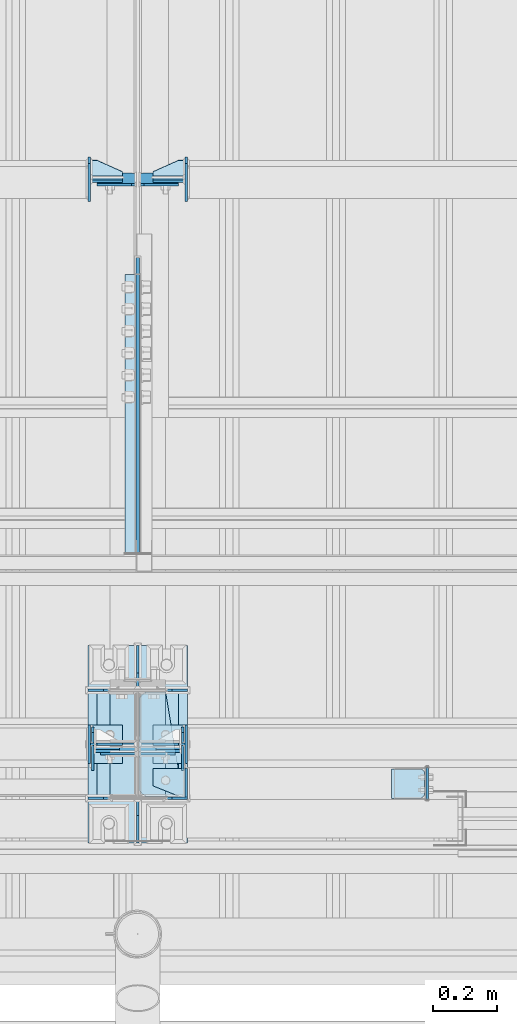
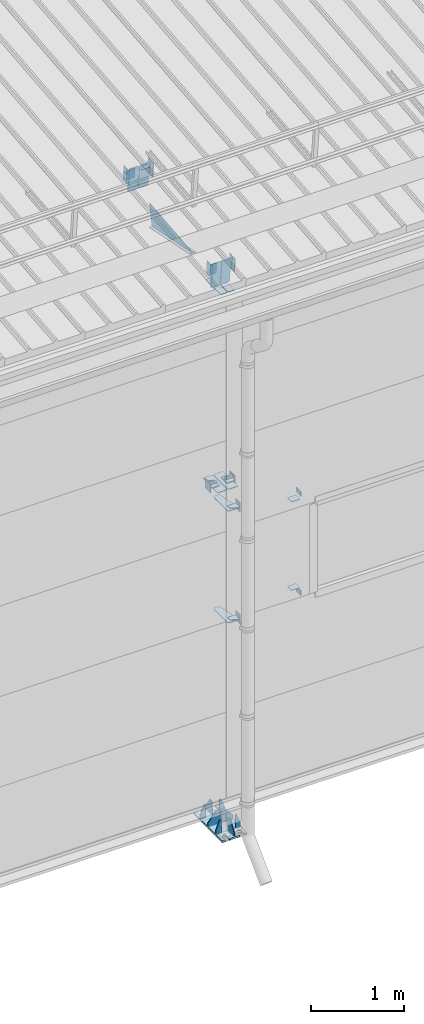
# One storey, part 121 of 709: 45 plates, 4 openings, 11 elements without a shape of their own.
"""IFC4 building model written with IfcOpenShell, lengths in millimetres."""

from ifc_helpers import new_model, si_unit, direction, frame, origin_with_axes, place, context, subcontext, project, spatial, line, arc, indexed_curve, outline, extrude, material, element, aggregate, save


model = new_model("IFC4")

# Units and contexts
model_context = context("Model", 3, precision=0.2, world=origin_with_axes(), true_north=direction((0.0, 1.0)))
body_context = subcontext(model_context, "Body", "Model", "MODEL_VIEW")
ifc_project = project(units=[si_unit("LENGTHUNIT", "METRE", prefix="MILLI"), si_unit("AREAUNIT", "SQUARE_METRE"), si_unit("VOLUMEUNIT", "CUBIC_METRE"), si_unit("MASSUNIT", "GRAM", prefix="KILO"), si_unit("TIMEUNIT", "SECOND"), si_unit("PLANEANGLEUNIT", "RADIAN"), si_unit("SOLIDANGLEUNIT", "STERADIAN"), si_unit("THERMODYNAMICTEMPERATUREUNIT", "DEGREE_CELSIUS"), si_unit("LUMINOUSINTENSITYUNIT", "LUMEN")], contexts=[model_context])

# Site, building, storey
site_placement = place(None, origin_with_axes())
site = spatial("IfcSite", under=ifc_project, at=site_placement, CompositionType="ELEMENT")
building_placement = place(site_placement, origin_with_axes())
building = spatial("IfcBuilding", under=site, at=building_placement, Name="Undefined", CompositionType="ELEMENT")
storey_placement = place(building_placement, origin_with_axes())
storey = spatial("IfcBuildingStorey", under=building, at=storey_placement, Name="Undefined", CompositionType="ELEMENT", Elevation=0.0)

# Assembly, plates, voiding features
assembly_1_placement = place(storey_placement, frame((16000.0, 173.0, -200.0), z_axis=(-1.0, 0.0, 0.0), x_axis=(0.0, 0.0, 1.0)))
assembly_1 = element("IfcElementAssembly", 1, at=assembly_1_placement, inside=storey)
ifc_material = material(Name="C355-6", Category="STEEL")
plate_1_placement = place(assembly_1_placement, frame((7434.21546, -30.02526, 3.0), z_axis=(-0.099503719, -0.9950371902, 0.0), x_axis=(0.0, 0.0, 1.0)))
plate_1 = element("IfcPlate", 2, at=plate_1_placement, material=ifc_material, ObjectType="595", context=body_context, shape_type="SolidModel", body=[
    extrude(outline(indexed_curve([(0.0, 0.0), (114.0, 0.0), (114.0, 333.33554), (0.0, 333.33554)], segments=[line(1, 2, 3, 4, 1)])), frame((0.0, 0.0, 4.0), z_axis=(0.0, 0.0, 1.0), x_axis=(1.0, 0.0, 0.0)), (0.0, 0.0, -1.0), 8.0),
])
plate_2_placement = place(assembly_1_placement, frame((12.5, -308.0, 155.0), z_axis=(1.0, 0.0, 0.0), x_axis=(0.0, 0.0, -1.0)))
plate_2 = element("IfcPlate", 3, at=plate_2_placement, material=ifc_material, ObjectType="416", context=body_context, shape_type="SolidModel", body=[
    extrude(outline(indexed_curve([(0.0, 0.0), (310.0, 0.0), (310.0, 616.0), (0.0, 616.0)], segments=[line(1, 2, 3, 4, 1)])), frame((0.0, 0.0, 12.5), z_axis=(0.0, 0.0, 1.0), x_axis=(1.0, 0.0, 0.0)), (0.0, 0.0, -1.0), 25.0),
])
voiding_feature_1_placement = place(plate_2_placement, frame((40.0, 616.0, 0.0), z_axis=(0.0, 0.0, -1.0), x_axis=(1.0, 0.0, 0.0)))
element("IfcVoidingFeature", 4, at=voiding_feature_1_placement, cuts=plate_2, PredefinedType="HOLE", context=body_context, shape_type="SolidModel", body=[
    extrude(outline(indexed_curve([(0.0, 0.0), (50.0, 0.0), (50.0, 60.0), (42.67767, 77.67767), (25.0, 85.0), (25.0, 85.0), (7.32233, 77.67767), (0.0, 60.0)], segments=[line(1, 2, 3), arc(3, 4, 5), line(5, 6), arc(6, 7, 8), line(8, 1)])), frame((0.0, 0.0, 12.5), z_axis=(0.0, 0.0, 1.0), x_axis=(1.0, 0.0, 0.0)), (0.0, 0.0, -1.0), 25.0),
])
voiding_feature_2_placement = place(plate_2_placement, frame((40.0, 0.0, 0.0), z_axis=(0.0, 0.0, 1.0), x_axis=(1.0, 0.0, 0.0)))
element("IfcVoidingFeature", 5, at=voiding_feature_2_placement, cuts=plate_2, PredefinedType="HOLE", context=body_context, shape_type="SolidModel", body=[
    extrude(outline(indexed_curve([(0.0, 0.0), (50.0, 0.0), (50.0, 60.0), (42.67767, 77.67767), (25.0, 85.0), (25.0, 85.0), (7.32233, 77.67767), (0.0, 60.0)], segments=[line(1, 2, 3), arc(3, 4, 5), line(5, 6), arc(6, 7, 8), line(8, 1)])), frame((0.0, 0.0, 12.5), z_axis=(0.0, 0.0, 1.0), x_axis=(1.0, 0.0, 0.0)), (0.0, 0.0, -1.0), 25.0),
])
voiding_feature_3_placement = place(plate_2_placement, frame((270.0, 616.0, 0.0), z_axis=(0.0, 0.0, 1.0), x_axis=(-1.0, 0.0, 0.0)))
element("IfcVoidingFeature", 6, at=voiding_feature_3_placement, cuts=plate_2, PredefinedType="HOLE", context=body_context, shape_type="SolidModel", body=[
    extrude(outline(indexed_curve([(0.0, 0.0), (50.0, 0.0), (50.0, 60.0), (42.67767, 77.67767), (25.0, 85.0), (25.0, 85.0), (7.32233, 77.67767), (0.0, 60.0)], segments=[line(1, 2, 3), arc(3, 4, 5), line(5, 6), arc(6, 7, 8), line(8, 1)])), frame((0.0, 0.0, 12.5), z_axis=(0.0, 0.0, 1.0), x_axis=(1.0, 0.0, 0.0)), (0.0, 0.0, -1.0), 25.0),
])
voiding_feature_4_placement = place(plate_2_placement, frame((270.0, 0.0, 0.0), z_axis=(0.0, 0.0, -1.0), x_axis=(-1.0, 0.0, 0.0)))
element("IfcVoidingFeature", 7, at=voiding_feature_4_placement, cuts=plate_2, PredefinedType="HOLE", context=body_context, shape_type="SolidModel", body=[
    extrude(outline(indexed_curve([(0.0, 0.0), (50.0, 0.0), (50.0, 60.0), (42.67767, 77.67767), (25.0, 85.0), (25.0, 85.0), (7.32233, 77.67767), (0.0, 60.0)], segments=[line(1, 2, 3), arc(3, 4, 5), line(5, 6), arc(6, 7, 8), line(8, 1)])), frame((0.0, 0.0, 12.5), z_axis=(0.0, 0.0, 1.0), x_axis=(1.0, 0.0, 0.0)), (0.0, 0.0, -1.0), 25.0),
])
plate_3_placement = place(assembly_1_placement, frame((25.0, -168.5, 87.0), z_axis=(0.0, 1.0, 0.0), x_axis=(0.0, 0.0, 1.0)))
plate_3 = element("IfcPlate", 8, at=plate_3_placement, material=ifc_material, ObjectType="419", context=body_context, shape_type="SolidModel", body=[
    extrude(outline(indexed_curve([(0.0, 0.0), (68.0, 0.0), (68.0, 50.0), (20.0, 175.0), (0.0, 175.0)], segments=[line(1, 2, 3, 4, 5, 1)])), frame((0.0, 0.0, 4.0), z_axis=(0.0, 0.0, 1.0), x_axis=(1.0, 0.0, 0.0)), (0.0, 0.0, -1.0), 8.0),
])
plate_4_placement = place(assembly_1_placement, frame((25.0, 168.5, 87.0), z_axis=(0.0, 1.0, 0.0), x_axis=(0.0, 0.0, 1.0)))
plate_4 = element("IfcPlate", 9, at=plate_4_placement, material=ifc_material, ObjectType="419", context=body_context, shape_type="SolidModel", body=[
    extrude(outline(indexed_curve([(0.0, 0.0), (68.0, 0.0), (68.0, 50.0), (20.0, 175.0), (0.0, 175.0)], segments=[line(1, 2, 3, 4, 5, 1)])), frame((0.0, 0.0, 4.0), z_axis=(0.0, 0.0, 1.0), x_axis=(1.0, 0.0, 0.0)), (0.0, 0.0, -1.0), 8.0),
])
plate_5_placement = place(assembly_1_placement, frame((25.0, 168.5, -87.0), z_axis=(0.0, -1.0, 0.0), x_axis=(0.0, 0.0, -1.0)))
plate_5 = element("IfcPlate", 10, at=plate_5_placement, material=ifc_material, ObjectType="419", context=body_context, shape_type="SolidModel", body=[
    extrude(outline(indexed_curve([(0.0, 0.0), (68.0, 0.0), (68.0, 50.0), (20.0, 175.0), (0.0, 175.0)], segments=[line(1, 2, 3, 4, 5, 1)])), frame((0.0, 0.0, 4.0), z_axis=(0.0, 0.0, 1.0), x_axis=(1.0, 0.0, 0.0)), (0.0, 0.0, -1.0), 8.0),
])
plate_6_placement = place(assembly_1_placement, frame((25.0, -168.5, -87.0), z_axis=(0.0, -1.0, 0.0), x_axis=(0.0, 0.0, -1.0)))
plate_6 = element("IfcPlate", 11, at=plate_6_placement, material=ifc_material, ObjectType="419", context=body_context, shape_type="SolidModel", body=[
    extrude(outline(indexed_curve([(0.0, 0.0), (68.0, 0.0), (68.0, 50.0), (20.0, 175.0), (0.0, 175.0)], segments=[line(1, 2, 3, 4, 5, 1)])), frame((0.0, 0.0, 4.0), z_axis=(0.0, 0.0, 1.0), x_axis=(1.0, 0.0, 0.0)), (0.0, 0.0, -1.0), 8.0),
])
plate_7_placement = place(assembly_1_placement, frame((25.0, -173.0, 0.0), z_axis=(0.0, 0.0, 1.0), x_axis=(0.0, -1.0, 0.0)))
plate_7 = element("IfcPlate", 12, at=plate_7_placement, material=ifc_material, ObjectType="418", context=body_context, shape_type="SolidModel", body=[
    extrude(outline(indexed_curve([(0.0, 0.0), (135.0, 0.0), (135.0, 50.0), (50.0, 175.0), (0.0, 175.0)], segments=[line(1, 2, 3, 4, 5, 1)])), frame((0.0, 0.0, 4.0), z_axis=(0.0, 0.0, 1.0), x_axis=(1.0, 0.0, 0.0)), (0.0, 0.0, -1.0), 8.0),
])
plate_8_placement = place(assembly_1_placement, frame((25.0, 173.0, 0.0), z_axis=(0.0, 0.0, -1.0), x_axis=(0.0, 1.0, 0.0)))
plate_8 = element("IfcPlate", 13, at=plate_8_placement, material=ifc_material, ObjectType="418", context=body_context, shape_type="SolidModel", body=[
    extrude(outline(indexed_curve([(0.0, 0.0), (135.0, 0.0), (135.0, 50.0), (50.0, 175.0), (0.0, 175.0)], segments=[line(1, 2, 3, 4, 5, 1)])), frame((0.0, 0.0, 4.0), z_axis=(0.0, 0.0, 1.0), x_axis=(1.0, 0.0, 0.0)), (0.0, 0.0, -1.0), 8.0),
])
plate_9_placement = place(assembly_1_placement, frame((25.0, 0.0, 3.0), z_axis=(0.0, 1.0, 0.0), x_axis=(0.0, 0.0, 1.0)))
plate_9 = element("IfcPlate", 14, at=plate_9_placement, material=ifc_material, ObjectType="417", context=body_context, shape_type="SolidModel", body=[
    extrude(outline(indexed_curve([(0.0, 0.0), (152.0, 0.0), (152.0, 50.0), (50.0, 175.0), (0.0, 175.0)], segments=[line(1, 2, 3, 4, 5, 1)])), frame((0.0, 0.0, 4.0), z_axis=(0.0, 0.0, 1.0), x_axis=(1.0, 0.0, 0.0)), (0.0, 0.0, -1.0), 8.0),
])
plate_10_placement = place(assembly_1_placement, frame((25.0, 0.0, -3.0), z_axis=(0.0, -1.0, 0.0), x_axis=(0.0, 0.0, -1.0)))
plate_10 = element("IfcPlate", 15, at=plate_10_placement, material=ifc_material, ObjectType="417", context=body_context, shape_type="SolidModel", body=[
    extrude(outline(indexed_curve([(0.0, 0.0), (152.0, 0.0), (152.0, 50.0), (50.0, 175.0), (0.0, 175.0)], segments=[line(1, 2, 3, 4, 5, 1)])), frame((0.0, 0.0, 4.0), z_axis=(0.0, 0.0, 1.0), x_axis=(1.0, 0.0, 0.0)), (0.0, 0.0, -1.0), 8.0),
])
plate_11_placement = place(assembly_1_placement, frame((7097.93718, -163.0, -87.0), z_axis=(-1.0, 0.0, 0.0), x_axis=(0.0, 0.0, 1.0)))
plate_11 = element("IfcPlate", 16, at=plate_11_placement, material=ifc_material, ObjectType="461", context=body_context, shape_type="SolidModel", body=[
    extrude(outline(indexed_curve([(0.0, 0.0), (68.0, 0.0), (83.0, 15.0), (83.0, 311.0), (68.0, 326.0), (0.0, 326.0)], segments=[line(1, 2, 3, 4, 5, 6, 1)])), frame((0.0, 0.0, 4.0), z_axis=(0.0, 0.0, 1.0), x_axis=(1.0, 0.0, 0.0)), (0.0, 0.0, -1.0), 8.0),
])
plate_12_placement = place(assembly_1_placement, frame((7097.93718, 163.0, 87.0), z_axis=(-1.0, 0.0, 0.0), x_axis=(0.0, 0.0, -1.0)))
plate_12 = element("IfcPlate", 17, at=plate_12_placement, material=ifc_material, ObjectType="461", context=body_context, shape_type="SolidModel", body=[
    extrude(outline(indexed_curve([(0.0, 0.0), (68.0, 0.0), (83.0, 15.0), (83.0, 311.0), (68.0, 326.0), (0.0, 326.0)], segments=[line(1, 2, 3, 4, 5, 6, 1)])), frame((0.0, 0.0, 4.0), z_axis=(0.0, 0.0, 1.0), x_axis=(1.0, 0.0, 0.0)), (0.0, 0.0, -1.0), 8.0),
])
plate_13_placement = place(assembly_1_placement, frame((4502.0, 163.0, 127.0), z_axis=(-1.0, 0.0, 0.0), x_axis=(0.0, 0.0, -1.0)))
plate_13 = element("IfcPlate", 18, at=plate_13_placement, material=ifc_material, ObjectType="547", context=body_context, shape_type="SolidModel", body=[
    extrude(outline(indexed_curve([(0.0, 0.0), (108.0, 0.0), (123.0, 15.0), (123.0, 311.0), (108.0, 326.0), (0.0, 326.0)], segments=[line(1, 2, 3, 4, 5, 6, 1)])), frame((0.0, 0.0, 4.0), z_axis=(0.0, 0.0, 1.0), x_axis=(1.0, 0.0, 0.0)), (0.0, 0.0, -1.0), 8.0),
])
plate_14_placement = place(assembly_1_placement, frame((2742.0, -163.0, -4.0), z_axis=(1.0, 0.0, 0.0), x_axis=(0.0, 0.0, -1.0)))
plate_14 = element("IfcPlate", 19, at=plate_14_placement, material=ifc_material, ObjectType="543", context=body_context, shape_type="SolidModel", body=[
    extrude(outline(indexed_curve([(0.0, 20.0), (20.0, 0.0), (123.0, 0.0), (123.0, 86.0), (83.0, 326.0), (20.0, 326.0), (0.0, 306.0)], segments=[line(1, 2, 3, 4, 5, 6, 7, 1)])), frame((0.0, 0.0, 4.0), z_axis=(0.0, 0.0, 1.0), x_axis=(1.0, 0.0, 0.0)), (0.0, 0.0, -1.0), 8.0),
])
plate_15_placement = place(assembly_1_placement, frame((4212.0, -163.0, -4.0), z_axis=(1.0, 0.0, 0.0), x_axis=(0.0, 0.0, -1.0)))
plate_15 = element("IfcPlate", 20, at=plate_15_placement, material=ifc_material, ObjectType="543", context=body_context, shape_type="SolidModel", body=[
    extrude(outline(indexed_curve([(0.0, 20.0), (20.0, 0.0), (123.0, 0.0), (123.0, 86.0), (83.0, 326.0), (20.0, 326.0), (0.0, 306.0)], segments=[line(1, 2, 3, 4, 5, 6, 7, 1)])), frame((0.0, 0.0, 4.0), z_axis=(0.0, 0.0, 1.0), x_axis=(1.0, 0.0, 0.0)), (0.0, 0.0, -1.0), 8.0),
])
plate_16_placement = place(assembly_1_placement, frame((4502.0, -163.0, -127.0), z_axis=(-1.0, 0.0, 0.0), x_axis=(0.0, 0.0, 1.0)))
plate_16 = element("IfcPlate", 21, at=plate_16_placement, material=ifc_material, ObjectType="547", context=body_context, shape_type="SolidModel", body=[
    extrude(outline(indexed_curve([(0.0, 0.0), (108.0, 0.0), (123.0, 15.0), (123.0, 311.0), (108.0, 326.0), (0.0, 326.0)], segments=[line(1, 2, 3, 4, 5, 6, 1)])), frame((0.0, 0.0, 4.0), z_axis=(0.0, 0.0, 1.0), x_axis=(1.0, 0.0, 0.0)), (0.0, 0.0, -1.0), 8.0),
])
plate_17_placement = place(assembly_1_placement, frame((7434.21546, -30.02526, -3.0), z_axis=(0.099503719, 0.9950371902, 0.0), x_axis=(0.0, 0.0, -1.0)))
plate_17 = element("IfcPlate", 22, at=plate_17_placement, material=ifc_material, ObjectType="595", context=body_context, shape_type="SolidModel", body=[
    extrude(outline(indexed_curve([(0.0, 0.0), (114.0, 0.0), (114.0, 332.53554), (0.0, 332.53554)], segments=[line(1, 2, 3, 4, 1)])), frame((0.0, 0.0, 4.0), z_axis=(0.0, 0.0, 1.0), x_axis=(1.0, 0.0, 0.0)), (0.0, 0.0, -1.0), 8.0),
])
aggregate(assembly_1, [plate_1, plate_2, plate_3, plate_4, plate_5, plate_6, plate_7, plate_8, plate_9, plate_10, plate_11, plate_12, plate_13, plate_14, plate_15, plate_16, plate_17])

# Assembly, plates
assembly_2_placement = place(storey_placement, frame((16000.0, 346.0, 7089.70002), z_axis=(1.0, 0.0, 0.0), x_axis=(0.0, 0.9950371902, 0.099503719)))
assembly_2 = element("IfcElementAssembly", 23, at=assembly_2_placement, inside=storey)
plate_18_placement = place(assembly_2_placement, frame((1597.88359, 163.0, 127.0), z_axis=(-1.0, 0.0, 0.0), x_axis=(0.0, 0.0, -1.0)))
plate_18 = element("IfcPlate", 24, at=plate_18_placement, material=ifc_material, ObjectType="585", context=body_context, shape_type="SolidModel", body=[
    extrude(outline(indexed_curve([(0.0, 0.0), (108.0, 0.0), (123.0, 15.0), (123.0, 311.0), (108.0, 326.0), (0.0, 326.0)], segments=[line(1, 2, 3, 4, 5, 6, 1)])), frame((0.0, 0.0, 4.0), z_axis=(0.0, 0.0, 1.0), x_axis=(1.0, 0.0, 0.0)), (0.0, 0.0, -1.0), 8.0),
])
plate_19_placement = place(assembly_2_placement, frame((1597.88359, 163.0, -127.0), z_axis=(1.0, 0.0, 0.0), x_axis=(0.0, 0.0, 1.0)))
plate_19 = element("IfcPlate", 25, at=plate_19_placement, material=ifc_material, ObjectType="585", context=body_context, shape_type="SolidModel", body=[
    extrude(outline(indexed_curve([(0.0, 0.0), (108.0, 0.0), (123.0, 15.0), (123.0, 311.0), (108.0, 326.0), (0.0, 326.0)], segments=[line(1, 2, 3, 4, 5, 6, 1)])), frame((0.0, 0.0, 4.0), z_axis=(0.0, 0.0, 1.0), x_axis=(1.0, 0.0, 0.0)), (0.0, 0.0, -1.0), 8.0),
])
plate_20_placement = place(assembly_2_placement, frame((1336.51563, -171.28713, 0.0), z_axis=(0.0, 0.0, 1.0), x_axis=(-1.0, 0.0, 0.0)))
plate_20 = element("IfcPlate", 26, at=plate_20_placement, material=ifc_material, ObjectType="449", context=body_context, shape_type="SolidModel", body=[
    extrude(outline(indexed_curve([(0.0, 0.0), (928.3198, 0.0), (79.53997, 259.83056)], segments=[line(1, 2, 3, 1)])), frame((0.0, 0.0, 6.0), z_axis=(0.0, 0.0, 1.0), x_axis=(1.0, 0.0, 0.0)), (0.0, 0.0, -1.0), 12.0),
])
plate_21_placement = place(assembly_2_placement, frame((1255.8048, -434.94249, -40.0), z_axis=(0.2927142719, 0.9561999556, 0.0), x_axis=(-0.9561999556, 0.2927142719, 0.0)))
plate_21 = element("IfcPlate", 27, at=plate_21_placement, material=ifc_material, ObjectType="450", context=body_context, shape_type="SolidModel", body=[
    extrude(outline(indexed_curve([(0.0, 0.0), (887.65935, 0.0), (887.65935, 80.0), (0.0, 80.0)], segments=[line(1, 2, 3, 4, 1)])), frame((0.0, 0.0, 4.0), z_axis=(0.0, 0.0, 1.0), x_axis=(1.0, 0.0, 0.0)), (0.0, 0.0, -1.0), 8.0),
])
aggregate(assembly_2, [plate_18, plate_19, plate_20, plate_21])

assembly_3_placement = place(storey_placement, frame((10000.0, 173.0, 4310.0), z_axis=(0.0, 0.0, -1.0), x_axis=(1.0, 0.0, 0.0)))
assembly_3 = element("IfcElementAssembly", 28, at=assembly_3_placement, inside=storey)
plate_22_placement = place(assembly_3_placement, frame((5849.0, -60.0, 60.0), z_axis=(1.0, 0.0, 0.0), x_axis=(0.0, 0.0, -1.0)))
plate_22 = element("IfcPlate", 29, at=plate_22_placement, material=ifc_material, ObjectType="506", context=body_context, shape_type="SolidModel", body=[
    extrude(outline(indexed_curve([(0.0, 0.0), (120.0, 0.0), (120.0, 120.0), (0.0, 120.0)], segments=[line(1, 2, 3, 4, 1)])), frame((0.0, 0.0, 4.0), z_axis=(0.0, 0.0, 1.0), x_axis=(1.0, 0.0, 0.0)), (0.0, 0.0, -1.0), 8.0),
])
plate_23_placement = place(assembly_3_placement, frame((5953.0, -60.0, 0.0), z_axis=(0.0, 0.0, 1.0), x_axis=(0.0, 1.0, 0.0)))
plate_23 = element("IfcPlate", 30, at=plate_23_placement, material=ifc_material, ObjectType="507", context=body_context, shape_type="SolidModel", body=[
    extrude(outline(indexed_curve([(0.0, 0.0), (120.0, 0.0), (120.0, 100.0), (0.0, 100.0)], segments=[line(1, 2, 3, 4, 1)])), frame((0.0, 0.0, 4.0), z_axis=(0.0, 0.0, 1.0), x_axis=(1.0, 0.0, 0.0)), (0.0, 0.0, -1.0), 8.0),
])
plate_24_placement = place(assembly_3_placement, frame((5953.0, 0.0, -60.0), z_axis=(0.0, -1.0, 0.0), x_axis=(0.0, 0.0, 1.0)))
plate_24 = element("IfcPlate", 31, at=plate_24_placement, material=ifc_material, ObjectType="508", context=body_context, shape_type="SolidModel", body=[
    extrude(outline(indexed_curve([(0.0, 80.0), (36.0, 0.0), (56.0, 0.0), (56.0, 90.0), (46.0, 100.0), (0.0, 100.0)], segments=[line(1, 2, 3, 4, 5, 6, 1)])), frame((0.0, 0.0, 4.0), z_axis=(0.0, 0.0, 1.0), x_axis=(1.0, 0.0, 0.0)), (0.0, 0.0, -1.0), 8.0),
])
aggregate(assembly_3, [plate_22, plate_23, plate_24])

assembly_4_placement = place(storey_placement, frame((16000.0, 50.0, 2550.0), z_axis=(0.0, 0.0, -1.0), x_axis=(1.0, 0.0, 0.0)))
assembly_4 = element("IfcElementAssembly", 32, at=assembly_4_placement, inside=storey)
plate_25_placement = place(assembly_4_placement, frame((47.0, 47.0, 0.0), z_axis=(0.0, 0.0, 1.0), x_axis=(0.0, -1.0, 0.0)))
plate_25 = element("IfcPlate", 33, at=plate_25_placement, material=ifc_material, ObjectType="502", context=body_context, shape_type="SolidModel", body=[
    extrude(outline(indexed_curve([(0.0, 100.0), (40.0, 0.0), (94.0, 0.0), (94.0, 100.0), (0.0, 100.0)], segments=[line(1, 2, 3, 4, 5, 1)])), frame((0.0, 0.0, 4.0), z_axis=(0.0, 0.0, 1.0), x_axis=(1.0, 0.0, 0.0)), (0.0, 0.0, -1.0), 8.0),
])
plate_26_placement = place(assembly_4_placement, frame((151.0, 47.0, -60.0), z_axis=(-1.0, 0.0, 0.0), x_axis=(0.0, -1.0, 0.0)))
plate_26 = element("IfcPlate", 34, at=plate_26_placement, material=ifc_material, ObjectType="501", context=body_context, shape_type="SolidModel", body=[
    extrude(outline(indexed_curve([(0.0, 0.0), (94.0, 0.0), (94.0, 120.0), (0.0, 120.0)], segments=[line(1, 2, 3, 4, 1)])), frame((0.0, 0.0, 4.0), z_axis=(0.0, 0.0, 1.0), x_axis=(1.0, 0.0, 0.0)), (0.0, 0.0, -1.0), 8.0),
])
plate_27_placement = place(assembly_4_placement, frame((904.0, 50.0, -50.0), z_axis=(-1.0, 0.0, 0.0), x_axis=(0.0, 0.0, -1.0)))
plate_27 = element("IfcPlate", 35, at=plate_27_placement, material=ifc_material, ObjectType="509", context=body_context, shape_type="SolidModel", body=[
    extrude(outline(indexed_curve([(0.0, 0.0), (65.0, 0.0), (65.0, 100.0), (0.0, 100.0)], segments=[line(1, 2, 3, 4, 1)])), frame((0.0, 0.0, 4.0), z_axis=(0.0, 0.0, 1.0), x_axis=(1.0, 0.0, 0.0)), (0.0, 0.0, -1.0), 8.0),
])
aggregate(assembly_4, [plate_25, plate_26, plate_27])

assembly_5_placement = place(storey_placement, frame((16000.0, 50.0, 4020.0), z_axis=(0.0, 0.0, -1.0), x_axis=(1.0, 0.0, 0.0)))
assembly_5 = element("IfcElementAssembly", 36, at=assembly_5_placement, inside=storey)
plate_28_placement = place(assembly_5_placement, frame((151.0, 47.0, -60.0), z_axis=(-1.0, 0.0, 0.0), x_axis=(0.0, -1.0, 0.0)))
plate_28 = element("IfcPlate", 37, at=plate_28_placement, material=ifc_material, ObjectType="501", context=body_context, shape_type="SolidModel", body=[
    extrude(outline(indexed_curve([(0.0, 0.0), (94.0, 0.0), (94.0, 120.0), (0.0, 120.0)], segments=[line(1, 2, 3, 4, 1)])), frame((0.0, 0.0, 4.0), z_axis=(0.0, 0.0, 1.0), x_axis=(1.0, 0.0, 0.0)), (0.0, 0.0, -1.0), 8.0),
])
plate_29_placement = place(assembly_5_placement, frame((904.0, -50.0, 50.0), z_axis=(-1.0, 0.0, 0.0), x_axis=(0.0, 0.0, 1.0)))
plate_29 = element("IfcPlate", 38, at=plate_29_placement, material=ifc_material, ObjectType="509", context=body_context, shape_type="SolidModel", body=[
    extrude(outline(indexed_curve([(0.0, 0.0), (65.0, 0.0), (65.0, 100.0), (0.0, 100.0)], segments=[line(1, 2, 3, 4, 1)])), frame((0.0, 0.0, 4.0), z_axis=(0.0, 0.0, 1.0), x_axis=(1.0, 0.0, 0.0)), (0.0, 0.0, -1.0), 8.0),
])
plate_30_placement = place(assembly_5_placement, frame((47.0, 47.0, 0.0), z_axis=(0.0, 0.0, 1.0), x_axis=(0.0, -1.0, 0.0)))
plate_30 = element("IfcPlate", 39, at=plate_30_placement, material=ifc_material, ObjectType="502", context=body_context, shape_type="SolidModel", body=[
    extrude(outline(indexed_curve([(0.0, 100.0), (40.0, 0.0), (94.0, 0.0), (94.0, 100.0), (0.0, 100.0)], segments=[line(1, 2, 3, 4, 5, 1)])), frame((0.0, 0.0, 4.0), z_axis=(0.0, 0.0, 1.0), x_axis=(1.0, 0.0, 0.0)), (0.0, 0.0, -1.0), 8.0),
])
aggregate(assembly_5, [plate_28, plate_29, plate_30])

assembly_6_placement = place(storey_placement, frame((16850.0, 50.0, 2600.0), z_axis=(1.0, 0.0, 0.0), x_axis=(0.0, 0.0, 1.0)))
assembly_6 = element("IfcElementAssembly", 40, at=assembly_6_placement, inside=storey)
plate_31_placement = place(assembly_6_placement, frame((1267.0, 46.0, 46.0), z_axis=(1.0, 0.0, 0.0), x_axis=(0.0, -1.0, 0.0)))
plate_31 = element("IfcPlate", 41, at=plate_31_placement, material=ifc_material, ObjectType="510", context=body_context, shape_type="SolidModel", body=[
    extrude(outline(indexed_curve([(0.0, 10.0), (10.0, 0.0), (82.0, 0.0), (92.0, 10.0), (92.0, 104.0), (0.0, 104.0)], segments=[line(1, 2, 3, 4, 5, 6, 1)])), frame((0.0, 0.0, 4.0), z_axis=(0.0, 0.0, 1.0), x_axis=(1.0, 0.0, 0.0)), (0.0, 0.0, -1.0), 8.0),
])
plate_32_placement = place(assembly_6_placement, frame((103.0, -46.0, 46.0), z_axis=(-1.0, 0.0, 0.0), x_axis=(0.0, 1.0, 0.0)))
plate_32 = element("IfcPlate", 42, at=plate_32_placement, material=ifc_material, ObjectType="510", context=body_context, shape_type="SolidModel", body=[
    extrude(outline(indexed_curve([(0.0, 10.0), (10.0, 0.0), (82.0, 0.0), (92.0, 10.0), (92.0, 104.0), (0.0, 104.0)], segments=[line(1, 2, 3, 4, 5, 6, 1)])), frame((0.0, 0.0, 4.0), z_axis=(0.0, 0.0, 1.0), x_axis=(1.0, 0.0, 0.0)), (0.0, 0.0, -1.0), 8.0),
])
aggregate(assembly_6, [plate_31, plate_32])

assembly_7_placement = place(storey_placement, frame((16000.0, 173.0, 4310.0), z_axis=(0.0, 0.0, -1.0), x_axis=(1.0, 0.0, 0.0)))
assembly_7 = element("IfcElementAssembly", 43, at=assembly_7_placement, inside=storey)
plate_33_placement = place(assembly_7_placement, frame((47.0, 0.0, -60.0), z_axis=(0.0, 1.0, 0.0), x_axis=(0.0, 0.0, 1.0)))
plate_33 = element("IfcPlate", 44, at=plate_33_placement, material=ifc_material, ObjectType="508", context=body_context, shape_type="SolidModel", body=[
    extrude(outline(indexed_curve([(0.0, 80.0), (36.0, 0.0), (56.0, 0.0), (56.0, 90.0), (46.0, 100.0), (0.0, 100.0)], segments=[line(1, 2, 3, 4, 5, 6, 1)])), frame((0.0, 0.0, 4.0), z_axis=(0.0, 0.0, 1.0), x_axis=(1.0, 0.0, 0.0)), (0.0, 0.0, -1.0), 8.0),
])
plate_34_placement = place(assembly_7_placement, frame((151.0, 60.0, 60.0), z_axis=(-1.0, 0.0, 0.0), x_axis=(0.0, 0.0, -1.0)))
plate_34 = element("IfcPlate", 45, at=plate_34_placement, material=ifc_material, ObjectType="506", context=body_context, shape_type="SolidModel", body=[
    extrude(outline(indexed_curve([(0.0, 0.0), (120.0, 0.0), (120.0, 120.0), (0.0, 120.0)], segments=[line(1, 2, 3, 4, 1)])), frame((0.0, 0.0, 4.0), z_axis=(0.0, 0.0, 1.0), x_axis=(1.0, 0.0, 0.0)), (0.0, 0.0, -1.0), 8.0),
])
plate_35_placement = place(assembly_7_placement, frame((47.0, 60.0, 0.0), z_axis=(0.0, 0.0, 1.0), x_axis=(0.0, -1.0, 0.0)))
plate_35 = element("IfcPlate", 46, at=plate_35_placement, material=ifc_material, ObjectType="507", context=body_context, shape_type="SolidModel", body=[
    extrude(outline(indexed_curve([(0.0, 0.0), (120.0, 0.0), (120.0, 100.0), (0.0, 100.0)], segments=[line(1, 2, 3, 4, 1)])), frame((0.0, 0.0, 4.0), z_axis=(0.0, 0.0, 1.0), x_axis=(1.0, 0.0, 0.0)), (0.0, 0.0, -1.0), 8.0),
])
aggregate(assembly_7, [plate_33, plate_34, plate_35])

assembly_8_placement = place(storey_placement, frame((10000.0, 158.95533, 7154.40952), z_axis=(0.0, 0.9950371902, 0.099503719), x_axis=(1.0, 0.0, 0.0)))
assembly_8 = element("IfcElementAssembly", 47, at=assembly_8_placement, inside=storey)
plate_36_placement = place(assembly_8_placement, frame((5859.0, -87.0, 60.0), z_axis=(1.0, 0.0, 0.0), x_axis=(0.0, 0.0, -1.0)))
plate_36 = element("IfcPlate", 48, at=plate_36_placement, material=ifc_material, ObjectType="596", context=body_context, shape_type="SolidModel", body=[
    extrude(outline(indexed_curve([(0.0, 0.0), (120.0, 0.0), (120.0, 174.0), (0.0, 174.0)], segments=[line(1, 2, 3, 4, 1)])), frame((0.0, 0.0, 4.0), z_axis=(0.0, 0.0, 1.0), x_axis=(1.0, 0.0, 0.0)), (0.0, 0.0, -1.0), 8.0),
])
plate_37_placement = place(assembly_8_placement, frame((5943.0, 72.0, 0.0), z_axis=(0.0, 0.0, 1.0), x_axis=(-1.0, 0.0, 0.0)))
plate_37 = element("IfcPlate", 49, at=plate_37_placement, material=ifc_material, ObjectType="597", context=body_context, shape_type="SolidModel", body=[
    extrude(outline(indexed_curve([(0.0, 0.0), (80.0, 0.0), (80.0, 144.0), (0.0, 144.0)], segments=[line(1, 2, 3, 4, 1)])), frame((0.0, 0.0, 4.0), z_axis=(0.0, 0.0, 1.0), x_axis=(1.0, 0.0, 0.0)), (0.0, 0.0, -1.0), 8.0),
])
aggregate(assembly_8, [plate_36, plate_37])

assembly_9_placement = place(storey_placement, frame((10000.0, 1936.65012, 7322.12913), z_axis=(0.0, 0.9950371902, 0.099503719), x_axis=(1.0, 0.0, 0.0)))
assembly_9 = element("IfcElementAssembly", 50, at=assembly_9_placement, inside=storey)
plate_38_placement = place(assembly_9_placement, frame((5953.0, 0.0, 60.0), z_axis=(0.0, -1.0, 0.0), x_axis=(-1.0, 0.0, 0.0)))
plate_38 = element("IfcPlate", 51, at=plate_38_placement, material=ifc_material, ObjectType="588", context=body_context, shape_type="SolidModel", body=[
    extrude(outline(indexed_curve([(0.0, 36.0), (80.0, 0.0), (100.0, 0.0), (100.0, 56.0), (0.0, 56.0)], segments=[line(1, 2, 3, 4, 5, 1)])), frame((0.0, 0.0, 4.0), z_axis=(0.0, 0.0, 1.0), x_axis=(1.0, 0.0, 0.0)), (0.0, 0.0, -1.0), 8.0),
])
plate_39_placement = place(assembly_9_placement, frame((5953.0, 65.0, 0.0), z_axis=(0.0, 0.0, 1.0), x_axis=(-1.0, 0.0, 0.0)))
plate_39 = element("IfcPlate", 52, at=plate_39_placement, material=ifc_material, ObjectType="587", context=body_context, shape_type="SolidModel", body=[
    extrude(outline(indexed_curve([(0.0, 0.0), (100.0, 0.0), (100.0, 130.0), (0.0, 130.0)], segments=[line(1, 2, 3, 4, 1)])), frame((0.0, 0.0, 4.0), z_axis=(0.0, 0.0, 1.0), x_axis=(1.0, 0.0, 0.0)), (0.0, 0.0, -1.0), 8.0),
])
plate_40_placement = place(assembly_9_placement, frame((5849.0, -98.0, 60.0), z_axis=(1.0, 0.0, 0.0), x_axis=(0.0, 0.0, -1.0)))
plate_40 = element("IfcPlate", 53, at=plate_40_placement, material=ifc_material, ObjectType="586", context=body_context, shape_type="SolidModel", body=[
    extrude(outline(indexed_curve([(0.0, 0.0), (120.0, 0.0), (120.0, 196.0), (0.0, 196.0)], segments=[line(1, 2, 3, 4, 1)])), frame((0.0, 0.0, 4.0), z_axis=(0.0, 0.0, 1.0), x_axis=(1.0, 0.0, 0.0)), (0.0, 0.0, -1.0), 8.0),
])
aggregate(assembly_9, [plate_38, plate_39, plate_40])

assembly_10_placement = place(storey_placement, frame((16000.0, 158.95533, 7154.40952), z_axis=(0.0, 0.9950371902, 0.099503719), x_axis=(1.0, 0.0, 0.0)))
assembly_10 = element("IfcElementAssembly", 54, at=assembly_10_placement, inside=storey)
plate_41_placement = place(assembly_10_placement, frame((57.0, -72.0, 0.0), z_axis=(0.0, 0.0, 1.0), x_axis=(1.0, 0.0, 0.0)))
plate_41 = element("IfcPlate", 55, at=plate_41_placement, material=ifc_material, ObjectType="597", context=body_context, shape_type="SolidModel", body=[
    extrude(outline(indexed_curve([(0.0, 0.0), (80.0, 0.0), (80.0, 144.0), (0.0, 144.0)], segments=[line(1, 2, 3, 4, 1)])), frame((0.0, 0.0, 4.0), z_axis=(0.0, 0.0, 1.0), x_axis=(1.0, 0.0, 0.0)), (0.0, 0.0, -1.0), 8.0),
])
plate_42_placement = place(assembly_10_placement, frame((141.0, -87.0, -60.0), z_axis=(-1.0, 0.0, 0.0), x_axis=(0.0, 0.0, 1.0)))
plate_42 = element("IfcPlate", 56, at=plate_42_placement, material=ifc_material, ObjectType="596", context=body_context, shape_type="SolidModel", body=[
    extrude(outline(indexed_curve([(0.0, 0.0), (120.0, 0.0), (120.0, 174.0), (0.0, 174.0)], segments=[line(1, 2, 3, 4, 1)])), frame((0.0, 0.0, 4.0), z_axis=(0.0, 0.0, 1.0), x_axis=(1.0, 0.0, 0.0)), (0.0, 0.0, -1.0), 8.0),
])
aggregate(assembly_10, [plate_41, plate_42])

assembly_11_placement = place(storey_placement, frame((16000.0, 1936.65012, 7322.12913), z_axis=(0.0, 0.9950371902, 0.099503719), x_axis=(1.0, 0.0, 0.0)))
assembly_11 = element("IfcElementAssembly", 57, at=assembly_11_placement, inside=storey)
plate_43_placement = place(assembly_11_placement, frame((47.0, 0.0, 60.0), z_axis=(0.0, 1.0, 0.0), x_axis=(1.0, 0.0, 0.0)))
plate_43 = element("IfcPlate", 58, at=plate_43_placement, material=ifc_material, ObjectType="588", context=body_context, shape_type="SolidModel", body=[
    extrude(outline(indexed_curve([(0.0, 36.0), (80.0, 0.0), (100.0, 0.0), (100.0, 56.0), (0.0, 56.0)], segments=[line(1, 2, 3, 4, 5, 1)])), frame((0.0, 0.0, 4.0), z_axis=(0.0, 0.0, 1.0), x_axis=(1.0, 0.0, 0.0)), (0.0, 0.0, -1.0), 8.0),
])
plate_44_placement = place(assembly_11_placement, frame((47.0, -65.0, 0.0), z_axis=(0.0, 0.0, 1.0), x_axis=(1.0, 0.0, 0.0)))
plate_44 = element("IfcPlate", 59, at=plate_44_placement, material=ifc_material, ObjectType="587", context=body_context, shape_type="SolidModel", body=[
    extrude(outline(indexed_curve([(0.0, 0.0), (100.0, 0.0), (100.0, 130.0), (0.0, 130.0)], segments=[line(1, 2, 3, 4, 1)])), frame((0.0, 0.0, 4.0), z_axis=(0.0, 0.0, 1.0), x_axis=(1.0, 0.0, 0.0)), (0.0, 0.0, -1.0), 8.0),
])
plate_45_placement = place(assembly_11_placement, frame((151.0, -98.0, -60.0), z_axis=(-1.0, 0.0, 0.0), x_axis=(0.0, 0.0, 1.0)))
plate_45 = element("IfcPlate", 60, at=plate_45_placement, material=ifc_material, ObjectType="586", context=body_context, shape_type="SolidModel", body=[
    extrude(outline(indexed_curve([(0.0, 0.0), (120.0, 0.0), (120.0, 196.0), (0.0, 196.0)], segments=[line(1, 2, 3, 4, 1)])), frame((0.0, 0.0, 4.0), z_axis=(0.0, 0.0, 1.0), x_axis=(1.0, 0.0, 0.0)), (0.0, 0.0, -1.0), 8.0),
])
aggregate(assembly_11, [plate_43, plate_44, plate_45])

save(model, "model.ifc")
